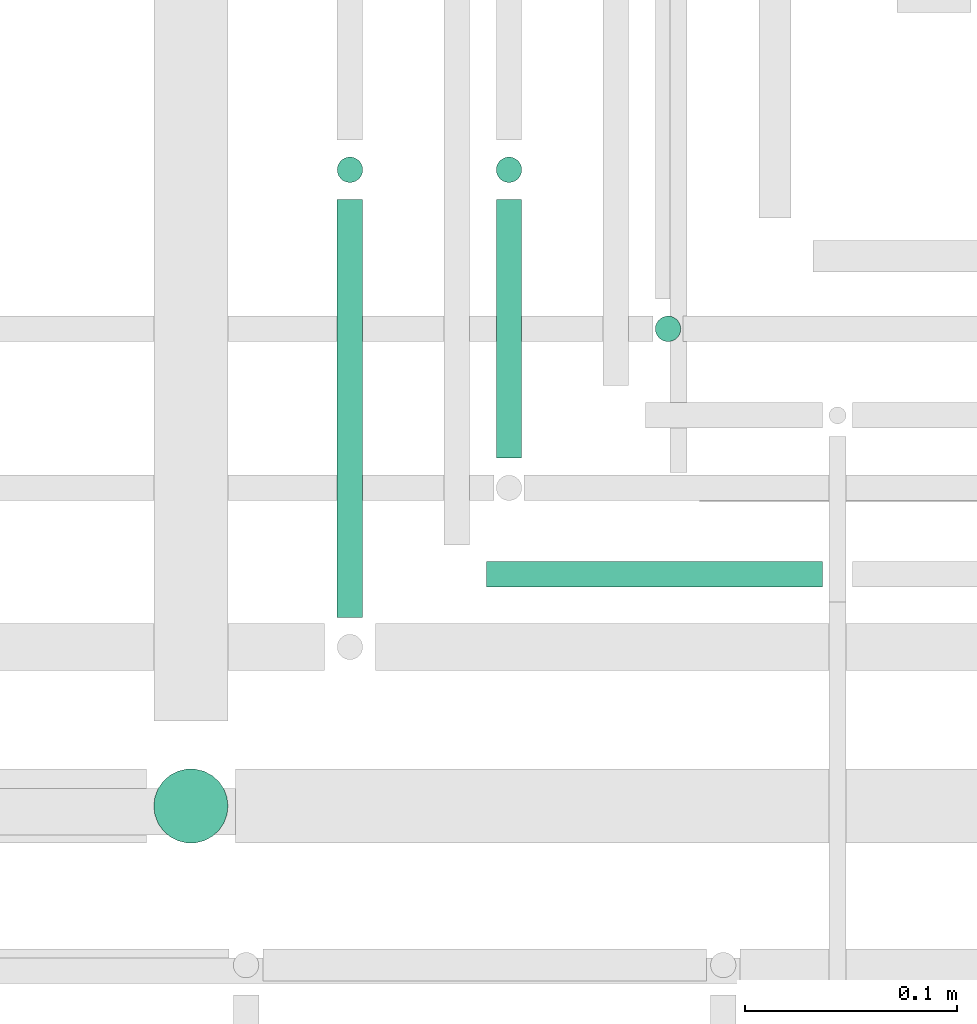
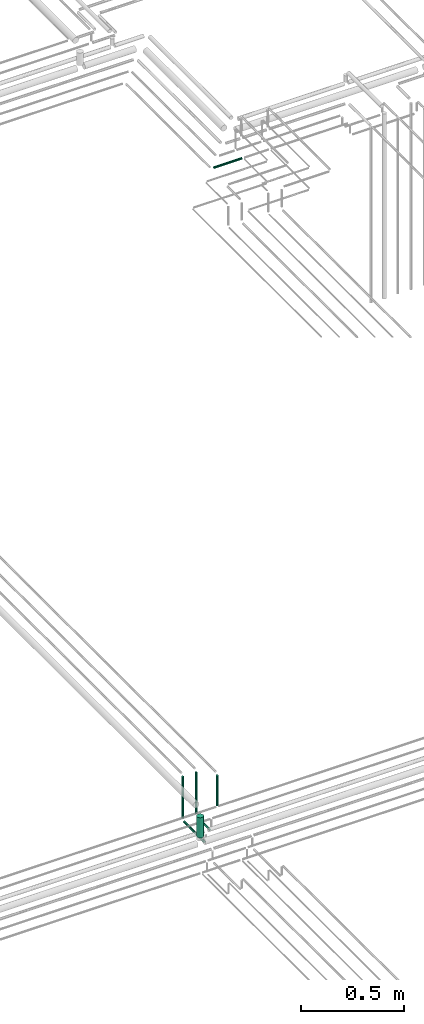
# One storey, part 219 of 331: 7 flow segments.
"""IFC2X3 building model written with IfcOpenShell, lengths in millimetres."""

from ifc_helpers import new_model, entity, si_unit, converted_unit, derived_unit, direction, frame, frame_2d, origin, origin_2d_with_axis, place, context, subcontext, project, spatial, circle, extrude, type_object, element, save


model = new_model("IFC2X3")

# Units and contexts
model_context = context("Model", 3, precision=0.01, world=origin(), true_north=direction((6.12303176911189e-17, 1.0)))
body_context = subcontext(model_context, "Body", "Model", "MODEL_VIEW")
ifc_project = project(units=[si_unit("LENGTHUNIT", "METRE", prefix="MILLI"), si_unit("AREAUNIT", "SQUARE_METRE"), si_unit("VOLUMEUNIT", "CUBIC_METRE"), converted_unit("PLANEANGLEUNIT", "DEGREE", entity("IfcRatioMeasure", 0.0174532925199433), si_unit("PLANEANGLEUNIT", "RADIAN"), dimensions=[0, 0, 0, 0, 0, 0, 0]), si_unit("MASSUNIT", "GRAM", prefix="KILO"), derived_unit("MASSDENSITYUNIT", [(si_unit("MASSUNIT", "GRAM", prefix="KILO"), 1), (si_unit("LENGTHUNIT", "METRE"), -3)]), derived_unit("MOMENTOFINERTIAUNIT", [(si_unit("LENGTHUNIT", "METRE"), 4)]), si_unit("TIMEUNIT", "SECOND"), si_unit("FREQUENCYUNIT", "HERTZ"), si_unit("THERMODYNAMICTEMPERATUREUNIT", "DEGREE_CELSIUS"), derived_unit("THERMALTRANSMITTANCEUNIT", [(si_unit("MASSUNIT", "GRAM", prefix="KILO"), 1), (si_unit("THERMODYNAMICTEMPERATUREUNIT", "KELVIN"), -1), (si_unit("TIMEUNIT", "SECOND"), -3)]), derived_unit("VOLUMETRICFLOWRATEUNIT", [(si_unit("LENGTHUNIT", "METRE"), 3), (si_unit("TIMEUNIT", "SECOND"), -1)]), derived_unit("MASSFLOWRATEUNIT", [(si_unit("MASSUNIT", "GRAM", prefix="KILO"), 1), (si_unit("TIMEUNIT", "SECOND"), -1)]), derived_unit("ROTATIONALFREQUENCYUNIT", [(si_unit("TIMEUNIT", "SECOND"), -1)]), si_unit("ELECTRICCURRENTUNIT", "AMPERE"), si_unit("ELECTRICVOLTAGEUNIT", "VOLT"), si_unit("POWERUNIT", "WATT"), si_unit("FORCEUNIT", "NEWTON", prefix="KILO"), si_unit("ILLUMINANCEUNIT", "LUX"), si_unit("LUMINOUSFLUXUNIT", "LUMEN"), si_unit("LUMINOUSINTENSITYUNIT", "CANDELA"), derived_unit("USERDEFINED", [(si_unit("MASSUNIT", "GRAM", prefix="KILO"), -1), (si_unit("LENGTHUNIT", "METRE"), -2), (si_unit("TIMEUNIT", "SECOND"), 3), (si_unit("LUMINOUSFLUXUNIT", "LUMEN"), 1)]), derived_unit("LINEARVELOCITYUNIT", [(si_unit("LENGTHUNIT", "METRE"), 1), (si_unit("TIMEUNIT", "SECOND"), -1)]), si_unit("PRESSUREUNIT", "PASCAL"), derived_unit("USERDEFINED", [(si_unit("LENGTHUNIT", "METRE"), -2), (si_unit("MASSUNIT", "GRAM", prefix="KILO"), 1), (si_unit("TIMEUNIT", "SECOND"), -2)]), derived_unit("LINEARFORCEUNIT", [(si_unit("MASSUNIT", "GRAM", prefix="KILO"), 1), (si_unit("LENGTHUNIT", "METRE"), 1), (si_unit("TIMEUNIT", "SECOND"), -2), (si_unit("LENGTHUNIT", "METRE"), -1)]), derived_unit("PLANARFORCEUNIT", [(si_unit("MASSUNIT", "GRAM", prefix="KILO"), 1), (si_unit("LENGTHUNIT", "METRE"), 1), (si_unit("TIMEUNIT", "SECOND"), -2), (si_unit("LENGTHUNIT", "METRE"), -2)])], contexts=[model_context])

# Site, building, storey
site_placement = place(None, frame((0.0, -0.00077364408347762, 0.0)))
site = spatial("IfcSite", under=ifc_project, at=site_placement, CompositionType="ELEMENT")
building_placement = place(site_placement, origin())
building = spatial("IfcBuilding", under=site, at=building_placement, CompositionType="ELEMENT")
storey_placement = place(building_placement, origin())
storey = spatial("IfcBuildingStorey", under=building, at=storey_placement, CompositionType="ELEMENT", Elevation=0.0)

# Flow segments
pipe_segment_type = type_object("IfcPipeSegmentType", PredefinedType="NOTDEFINED")
flow_segment_1_placement = place(storey_placement, frame((62137.5132590569, 8614.62056382737, 14467.4047277641)))
element("IfcFlowSegment", 1, at=flow_segment_1_placement, inside=storey, type_object=pipe_segment_type, context=body_context, shape_type="SweptSolid", body=[
    extrude(circle(Radius=6.0, at=frame_2d((0.0, -2.16573425859679e-12), x_axis=(1.0, 0.0))), frame((7.59527223591454, 0.0, 7.59527223591454), z_axis=(0.0, 1.0, 0.0), x_axis=(1.0, 0.0, 0.0)), (0.0, 0.0, 1.0), 122.0),
])
flow_segment_2_placement = place(storey_placement, frame((62137.5132590569, 8743.02529159144, 14489.0)))
element("IfcFlowSegment", 2, at=flow_segment_2_placement, inside=storey, type_object=pipe_segment_type, context=body_context, shape_type="SweptSolid", body=[
    extrude(circle(Radius=6.0, at=frame_2d((0.0, 1.08286712929839e-12), x_axis=(1.0, 0.0))), frame((7.59527223591454, 7.59527223591454, 0.0)), (0.0, 0.0, 1.0), 247.00000000002),
])
flow_segment_3_placement = place(storey_placement, frame((62062.5132590569, 8539.62056382736, 14467.4047277641)))
element("IfcFlowSegment", 3, at=flow_segment_3_placement, inside=storey, type_object=pipe_segment_type, context=body_context, shape_type="SweptSolid", body=[
    extrude(circle(Radius=6.0, at=frame_2d((0.0, -2.16573425859679e-12), x_axis=(1.0, 0.0))), frame((7.59527223591454, 0.0, 7.59527223591454), z_axis=(0.0, 1.0, 0.0), x_axis=(1.0, 0.0, 0.0)), (0.0, 0.0, 1.0), 197.000000000009),
])
flow_segment_4_placement = place(storey_placement, frame((62062.5132590569, 8743.02529159145, 14489.0)))
element("IfcFlowSegment", 4, at=flow_segment_4_placement, inside=storey, type_object=pipe_segment_type, context=body_context, shape_type="SweptSolid", body=[
    extrude(circle(Radius=6.0, at=origin_2d_with_axis()), frame((7.59527223591454, 7.59527223591562, 0.0), z_axis=(0.0, 0.0, 1.0), x_axis=(-1.0, 0.0, 0.0)), (0.0, 0.0, 1.0), 247.000000000024),
])
flow_segment_5_placement = place(storey_placement, frame((61976.0132590569, 8431.52529159141, 14590.0)))
element("IfcFlowSegment", 5, at=flow_segment_5_placement, inside=storey, type_object=pipe_segment_type, context=body_context, shape_type="SweptSolid", body=[
    extrude(circle(Radius=17.5, at=origin_2d_with_axis()), frame((19.0952722359119, 19.0952722359163, 0.0)), (0.0, 0.0, 1.0), 120.000000000033),
])
flow_segment_6_placement = place(storey_placement, frame((62212.513259057, 8668.02529159145, 14557.0)))
element("IfcFlowSegment", 6, at=flow_segment_6_placement, inside=storey, type_object=pipe_segment_type, context=body_context, shape_type="SweptSolid", body=[
    extrude(circle(Radius=6.0, at=origin_2d_with_axis()), frame((7.59527223591454, 7.59527223591562, 0.0), z_axis=(0.0, 0.0, 1.0), x_axis=(-1.0, 0.0, 0.0)), (0.0, 0.0, 1.0), 179.000000000024),
])
flow_segment_7_placement = place(storey_placement, frame((62134.5243524318, 8552.21546224651, 18442.4047277641)))
element("IfcFlowSegment", 7, at=flow_segment_7_placement, inside=storey, type_object=pipe_segment_type, context=body_context, shape_type="SweptSolid", body=[
    extrude(circle(Radius=6.0, at=frame_2d((3.24860138789518e-12, -2.16573425859679e-12), x_axis=(1.0, 0.0))), frame((0.0, 7.59527223591887, 7.59527223591887), z_axis=(1.0, 0.0, 0.0), x_axis=(0.0, 1.0, 0.0)), (0.0, 0.0, 1.0), 158.484451071291),
])

save(model, "model.ifc")
